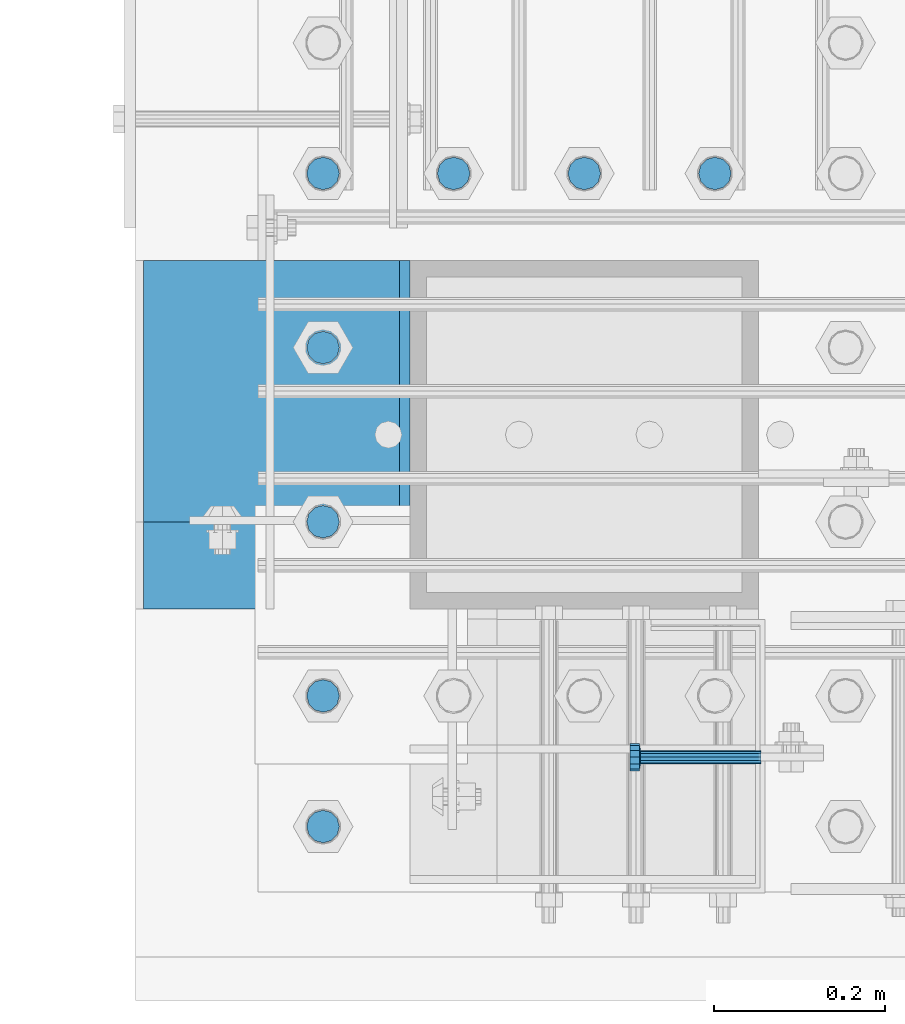
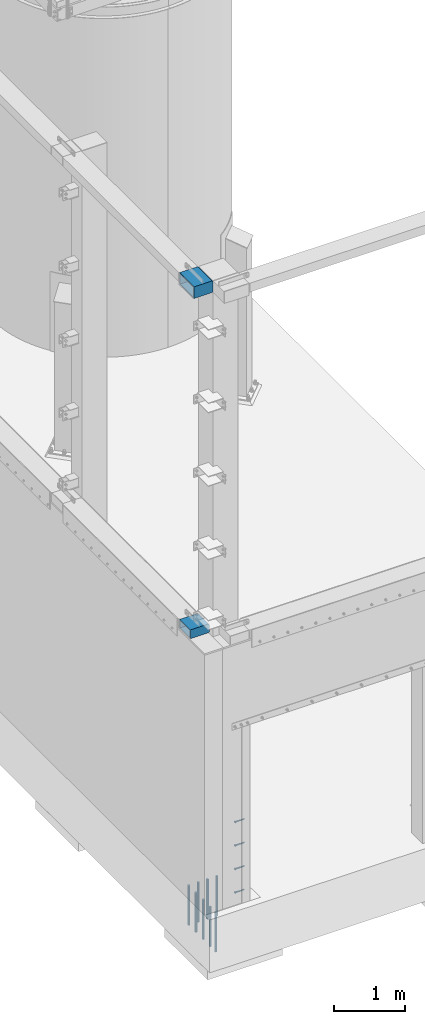
# One storey, part 1081 of 1876: 14 beams, 3 elements without a shape of their own.
"""IFC2X3 building model written with IfcOpenShell, lengths in millimetres."""

from ifc_helpers import new_model, si_unit, frame, origin_with_axes, place, context, subcontext, project, spatial, faceted_brep, material, type_object, element, aggregate, save


model = new_model("IFC2X3")

# Units and contexts
model_context = context("Model", 3, precision=1e-05, world=origin_with_axes())
body_context = subcontext(model_context, "Body", "Model", "MODEL_VIEW")
ifc_project = project(units=[si_unit("LENGTHUNIT", "METRE", prefix="MILLI"), si_unit("AREAUNIT", "SQUARE_METRE"), si_unit("VOLUMEUNIT", "CUBIC_METRE"), si_unit("MASSUNIT", "GRAM", prefix="KILO"), si_unit("TIMEUNIT", "SECOND"), si_unit("PLANEANGLEUNIT", "RADIAN"), si_unit("SOLIDANGLEUNIT", "STERADIAN"), si_unit("THERMODYNAMICTEMPERATUREUNIT", "DEGREE_CELSIUS"), si_unit("LUMINOUSINTENSITYUNIT", "LUMEN")], contexts=[model_context])

# Site, building, storey
site_placement = place(None, origin_with_axes())
site = spatial("IfcSite", under=ifc_project, at=site_placement, CompositionType="ELEMENT")
building_placement = place(site_placement, origin_with_axes())
building = spatial("IfcBuilding", under=site, at=building_placement, Name="Undefined", CompositionType="ELEMENT")
storey_placement = place(building_placement, origin_with_axes())
storey = spatial("IfcBuildingStorey", under=building, at=storey_placement, Name="Undefined", CompositionType="ELEMENT", Elevation=0.0)

# Assembly, beam
assembly_1_placement = place(storey_placement, origin_with_axes())
assembly_1 = element("IfcElementAssembly", 1, at=assembly_1_placement, inside=storey, Name="COLUMN", AssemblyPlace="NOTDEFINED", PredefinedType="RIGID_FRAME")
ifc_material_1 = material()
beam_type_1 = type_object("IfcBeamType", Name="HSS12X6X1/2", PredefinedType="NOTDEFINED")
beam_1_placement = place(assembly_1_placement, frame((-292.100000000004, -25349.2, 4597.4), z_axis=(0.0, 1.0, 0.0), x_axis=(1.0, 0.0, 0.0)))
beam_1 = element("IfcBeam", 2, at=beam_1_placement, type_object=beam_type_1, material=ifc_material_1, Name="BEAM", ObjectType="HSS12X6X1/2", context=body_context, shape_type="Brep", body=[
    faceted_brep([(9.52499999999452, 63.5, 139.700000000001), (9.52499999999452, 63.5, -139.700000000001), (320.675000000004, 63.5, -139.700000000001), (320.675000000004, 63.5, 139.700000000001), (9.52499999999452, -76.1999999999998, -152.400000000001), (9.52499999999452, -76.1999999999998, 152.400000000001), (9.52499999999452, 76.1999999999998, 152.400000000001), (9.52499999999452, 76.1999999999998, -152.400000000001), (9.52499999999452, -63.5, 139.700000000001), (9.52499999999452, -63.5, -139.700000000001), (307.975000000012, 76.1999999999998, 152.400000000001), (307.975000000012, 76.1999999999998, -152.400000000001), (320.675000000004, 63.5000000000073, -152.400000000001), (320.675000000004, 63.5000000000073, 152.400000000001), (320.675000000004, -63.5000000000018, 152.400000000001), (320.675000000004, -63.5, 139.700000000001), (320.675000000004, -63.5, -139.700000000001), (320.675000000004, -63.5000000000018, -152.400000000001), (307.975000000006, -76.1999999999998, -152.400000000001), (307.975000000006, -76.1999999999998, 152.400000000001)], [[[0, 1, 2, 3]], [[4, 5, 6, 7], [0, 8, 9, 1]], [[7, 6, 10, 11]], [[2, 12, 11, 10, 13, 3]], [[3, 13, 14, 15]], [[8, 0, 3, 15]], [[9, 8, 15, 16]], [[1, 9, 16, 2]], [[12, 2, 16, 17]], [[4, 7, 11, 12, 17, 18]], [[5, 4, 18, 19]], [[13, 10, 6, 5, 19, 14]], [[18, 17, 16, 15, 14, 19]]]),
])

# Assembly, beams
assembly_2_placement = place(storey_placement, origin_with_axes())
assembly_2 = element("IfcElementAssembly", 3, at=assembly_2_placement, inside=storey, Name="BENT PLATE", AssemblyPlace="NOTDEFINED", PredefinedType="RIGID_FRAME")
ifc_material_2 = material(Name="STEEL/A108")
beam_type_2 = type_object("IfcBeamType", Name="STUD_5/8-DIA", PredefinedType="NOTDEFINED")
beam_2_placement = place(assembly_2_placement, frame((437.751629702038, -25776.2375096436, 1320.8), z_axis=(0.0, 0.0, 1.0), x_axis=(-1.0, 0.0, 0.0)))
beam_2 = element("IfcBeam", 4, at=beam_2_placement, type_object=beam_type_2, material=ifc_material_2, Name="WELDED HEADED STUD", ObjectType="STUD_5/8-DIA", context=body_context, shape_type="Brep", body=[
    faceted_brep([(0.0, -7.94000005722046, 0.0), (0.0, -6.86999988555908, -3.97000002861023), (140.207082738083, -6.86999988555908, -3.97000002861023), (140.207082738083, -7.94000005722046, 0.0), (0.0, -3.97000002861023, -6.86999988555908), (140.207082738083, -3.97000002861023, -6.86999988555908), (0.0, 0.0, -7.94000005722046), (140.207082738083, 0.0, -7.94000005722046), (0.0, 3.97000002861023, -6.86999988555908), (140.207082738083, 3.97000002861023, -6.86999988555908), (0.0, 6.86999988555908, -3.97000002861023), (140.207082738083, 6.86999988555908, -3.97000002861023), (0.0, 7.94000005722046, 0.0), (140.207082738083, 7.94000005722046, 0.0), (0.0, 6.86999988555908, 3.97000002861023), (140.207082738083, 6.86999988555908, 3.97000002861023), (0.0, 3.97000002861023, 6.86999988555908), (140.207082738083, 3.97000002861023, 6.86999988555908), (0.0, 0.0, 7.94000005722046), (140.207082738083, 0.0, 7.94000005722046), (0.0, -3.97000002861023, 6.86999988555908), (140.207082738083, -3.97000002861023, 6.86999988555908), (0.0, -6.86999988555908, 3.97000002861023), (140.207082738083, -6.86999988555908, 3.97000002861023), (141.731072767845, -13.75, -7.94000005722046), (141.731072767845, -15.8800001144409, 0.0), (141.731072767845, -7.94000005722046, -13.75), (141.731072767845, 0.0, -15.8800001144409), (141.731072767845, 7.94000005722046, -13.75), (141.731072767845, 13.75, -7.94000005722046), (141.731072767845, 15.8800001144409, 0.0), (141.731072767845, 13.75, 7.94000005722046), (141.731072767845, 7.94000005722046, 13.75), (141.731072767845, 0.0, 15.8800001144409), (141.731072767845, -7.94000005722046, 13.75), (141.731072767845, -13.75, 7.94000005722046), (152.399002976177, -13.75, -7.94000005722046), (152.399002976177, -15.8800001144409, 0.0), (152.399002976177, -7.94000005722046, -13.75), (152.399002976177, 0.0, -15.8800001144409), (152.399002976177, 7.94000005722046, -13.75), (152.399002976177, 13.75, -7.94000005722046), (152.399002976177, 15.8800001144409, 0.0), (152.399002976177, 13.75, 7.94000005722046), (152.399002976177, 7.94000005722046, 13.75), (152.399002976177, 0.0, 15.8800001144409), (152.399002976177, -7.94000005722046, 13.75), (152.399002976177, -13.75, 7.94000005722046)], [[[0, 1, 2, 3]], [[1, 4, 5, 2]], [[4, 6, 7, 5]], [[6, 8, 9, 7]], [[8, 10, 11, 9]], [[10, 12, 13, 11]], [[12, 14, 15, 13]], [[14, 16, 17, 15]], [[16, 18, 19, 17]], [[18, 20, 21, 19]], [[20, 22, 23, 21]], [[22, 0, 3, 23]], [[22, 20, 18, 16, 14, 12, 10, 8, 6, 4, 1, 0]], [[3, 2, 24, 25]], [[2, 5, 26, 24]], [[5, 7, 27, 26]], [[7, 9, 28, 27]], [[9, 11, 29, 28]], [[11, 13, 30, 29]], [[13, 15, 31, 30]], [[15, 17, 32, 31]], [[17, 19, 33, 32]], [[19, 21, 34, 33]], [[21, 23, 35, 34]], [[23, 3, 25, 35]], [[25, 24, 36, 37]], [[24, 26, 38, 36]], [[26, 27, 39, 38]], [[27, 28, 40, 39]], [[28, 29, 41, 40]], [[29, 30, 42, 41]], [[30, 31, 43, 42]], [[31, 32, 44, 43]], [[32, 33, 45, 44]], [[33, 34, 46, 45]], [[34, 35, 47, 46]], [[35, 25, 37, 47]], [[38, 39, 40, 41, 42, 43, 44, 45, 46, 47, 37, 36]]]),
])
beam_3_placement = place(assembly_2_placement, frame((437.751629702038, -25776.2375096436, 914.4), z_axis=(0.0, 0.0, 1.0), x_axis=(-1.0, 0.0, 0.0)))
beam_3 = element("IfcBeam", 5, at=beam_3_placement, type_object=beam_type_2, material=ifc_material_2, Name="WELDED HEADED STUD", ObjectType="STUD_5/8-DIA", context=body_context, shape_type="Brep", body=[
    faceted_brep([(0.0, -7.94000005722046, 0.0), (0.0, -6.86999988555908, -3.97000002861023), (140.207082738083, -6.86999988555908, -3.97000002861023), (140.207082738083, -7.94000005722046, 0.0), (0.0, -3.97000002861023, -6.86999988555908), (140.207082738083, -3.97000002861023, -6.86999988555908), (0.0, 0.0, -7.94000005722046), (140.207082738083, 0.0, -7.94000005722046), (0.0, 3.97000002861023, -6.86999988555908), (140.207082738083, 3.97000002861023, -6.86999988555908), (0.0, 6.86999988555908, -3.97000002861023), (140.207082738083, 6.86999988555908, -3.97000002861023), (0.0, 7.94000005722046, 0.0), (140.207082738083, 7.94000005722046, 0.0), (0.0, 6.86999988555908, 3.97000002861023), (140.207082738083, 6.86999988555908, 3.97000002861023), (0.0, 3.97000002861023, 6.86999988555908), (140.207082738083, 3.97000002861023, 6.86999988555908), (0.0, 0.0, 7.94000005722046), (140.207082738083, 0.0, 7.94000005722046), (0.0, -3.97000002861023, 6.86999988555908), (140.207082738083, -3.97000002861023, 6.86999988555908), (0.0, -6.86999988555908, 3.97000002861023), (140.207082738083, -6.86999988555908, 3.97000002861023), (141.731072767845, -13.75, -7.94000005722046), (141.731072767845, -15.8800001144409, 0.0), (141.731072767845, -7.94000005722046, -13.75), (141.731072767845, 0.0, -15.8800001144409), (141.731072767845, 7.94000005722046, -13.75), (141.731072767845, 13.75, -7.94000005722046), (141.731072767845, 15.8800001144409, 0.0), (141.731072767845, 13.75, 7.94000005722046), (141.731072767845, 7.94000005722046, 13.75), (141.731072767845, 0.0, 15.8800001144409), (141.731072767845, -7.94000005722046, 13.75), (141.731072767845, -13.75, 7.94000005722046), (152.399002976177, -13.75, -7.94000005722046), (152.399002976177, -15.8800001144409, 0.0), (152.399002976177, -7.94000005722046, -13.75), (152.399002976177, 0.0, -15.8800001144409), (152.399002976177, 7.94000005722046, -13.75), (152.399002976177, 13.75, -7.94000005722046), (152.399002976177, 15.8800001144409, 0.0), (152.399002976177, 13.75, 7.94000005722046), (152.399002976177, 7.94000005722046, 13.75), (152.399002976177, 0.0, 15.8800001144409), (152.399002976177, -7.94000005722046, 13.75), (152.399002976177, -13.75, 7.94000005722046)], [[[0, 1, 2, 3]], [[1, 4, 5, 2]], [[4, 6, 7, 5]], [[6, 8, 9, 7]], [[8, 10, 11, 9]], [[10, 12, 13, 11]], [[12, 14, 15, 13]], [[14, 16, 17, 15]], [[16, 18, 19, 17]], [[18, 20, 21, 19]], [[20, 22, 23, 21]], [[22, 0, 3, 23]], [[22, 20, 18, 16, 14, 12, 10, 8, 6, 4, 1, 0]], [[3, 2, 24, 25]], [[2, 5, 26, 24]], [[5, 7, 27, 26]], [[7, 9, 28, 27]], [[9, 11, 29, 28]], [[11, 13, 30, 29]], [[13, 15, 31, 30]], [[15, 17, 32, 31]], [[17, 19, 33, 32]], [[19, 21, 34, 33]], [[21, 23, 35, 34]], [[23, 3, 25, 35]], [[25, 24, 36, 37]], [[24, 26, 38, 36]], [[26, 27, 39, 38]], [[27, 28, 40, 39]], [[28, 29, 41, 40]], [[29, 30, 42, 41]], [[30, 31, 43, 42]], [[31, 32, 44, 43]], [[32, 33, 45, 44]], [[33, 34, 46, 45]], [[34, 35, 47, 46]], [[35, 25, 37, 47]], [[38, 39, 40, 41, 42, 43, 44, 45, 46, 47, 37, 36]]]),
])
beam_4_placement = place(assembly_2_placement, frame((437.751629702038, -25776.2375096436, 508.0), z_axis=(0.0, 0.0, 1.0), x_axis=(-1.0, 0.0, 0.0)))
beam_4 = element("IfcBeam", 6, at=beam_4_placement, type_object=beam_type_2, material=ifc_material_2, Name="WELDED HEADED STUD", ObjectType="STUD_5/8-DIA", context=body_context, shape_type="Brep", body=[
    faceted_brep([(0.0, -7.94000005722046, 0.0), (0.0, -6.86999988555908, -3.97000002861023), (140.207082738083, -6.86999988555908, -3.97000002861023), (140.207082738083, -7.94000005722046, 0.0), (0.0, -3.97000002861023, -6.86999988555908), (140.207082738083, -3.97000002861023, -6.86999988555908), (0.0, 0.0, -7.94000005722046), (140.207082738083, 0.0, -7.94000005722046), (0.0, 3.97000002861023, -6.86999988555908), (140.207082738083, 3.97000002861023, -6.86999988555908), (0.0, 6.86999988555908, -3.97000002861023), (140.207082738083, 6.86999988555908, -3.97000002861023), (0.0, 7.94000005722046, 0.0), (140.207082738083, 7.94000005722046, 0.0), (0.0, 6.86999988555908, 3.97000002861023), (140.207082738083, 6.86999988555908, 3.97000002861023), (0.0, 3.97000002861023, 6.86999988555908), (140.207082738083, 3.97000002861023, 6.86999988555908), (0.0, 0.0, 7.94000005722046), (140.207082738083, 0.0, 7.94000005722046), (0.0, -3.97000002861023, 6.86999988555908), (140.207082738083, -3.97000002861023, 6.86999988555908), (0.0, -6.86999988555908, 3.97000002861023), (140.207082738083, -6.86999988555908, 3.97000002861023), (141.731072767845, -13.75, -7.94000005722046), (141.731072767845, -15.8800001144409, 0.0), (141.731072767845, -7.94000005722046, -13.75), (141.731072767845, 0.0, -15.8800001144409), (141.731072767845, 7.94000005722046, -13.75), (141.731072767845, 13.75, -7.94000005722046), (141.731072767845, 15.8800001144409, 0.0), (141.731072767845, 13.75, 7.94000005722046), (141.731072767845, 7.94000005722046, 13.75), (141.731072767845, 0.0, 15.8800001144409), (141.731072767845, -7.94000005722046, 13.75), (141.731072767845, -13.75, 7.94000005722046), (152.399002976177, -13.75, -7.94000005722046), (152.399002976177, -15.8800001144409, 0.0), (152.399002976177, -7.94000005722046, -13.75), (152.399002976177, 0.0, -15.8800001144409), (152.399002976177, 7.94000005722046, -13.75), (152.399002976177, 13.75, -7.94000005722046), (152.399002976177, 15.8800001144409, 0.0), (152.399002976177, 13.75, 7.94000005722046), (152.399002976177, 7.94000005722046, 13.75), (152.399002976177, 0.0, 15.8800001144409), (152.399002976177, -7.94000005722046, 13.75), (152.399002976177, -13.75, 7.94000005722046)], [[[0, 1, 2, 3]], [[1, 4, 5, 2]], [[4, 6, 7, 5]], [[6, 8, 9, 7]], [[8, 10, 11, 9]], [[10, 12, 13, 11]], [[12, 14, 15, 13]], [[14, 16, 17, 15]], [[16, 18, 19, 17]], [[18, 20, 21, 19]], [[20, 22, 23, 21]], [[22, 0, 3, 23]], [[22, 20, 18, 16, 14, 12, 10, 8, 6, 4, 1, 0]], [[3, 2, 24, 25]], [[2, 5, 26, 24]], [[5, 7, 27, 26]], [[7, 9, 28, 27]], [[9, 11, 29, 28]], [[11, 13, 30, 29]], [[13, 15, 31, 30]], [[15, 17, 32, 31]], [[17, 19, 33, 32]], [[19, 21, 34, 33]], [[21, 23, 35, 34]], [[23, 3, 25, 35]], [[25, 24, 36, 37]], [[24, 26, 38, 36]], [[26, 27, 39, 38]], [[27, 28, 40, 39]], [[28, 29, 41, 40]], [[29, 30, 42, 41]], [[30, 31, 43, 42]], [[31, 32, 44, 43]], [[32, 33, 45, 44]], [[33, 34, 46, 45]], [[34, 35, 47, 46]], [[35, 25, 37, 47]], [[38, 39, 40, 41, 42, 43, 44, 45, 46, 47, 37, 36]]]),
])
beam_5_placement = place(assembly_2_placement, frame((437.751629702038, -25776.2375096436, 101.6), z_axis=(0.0, 0.0, 1.0), x_axis=(-1.0, 0.0, 0.0)))
beam_5 = element("IfcBeam", 7, at=beam_5_placement, type_object=beam_type_2, material=ifc_material_2, Name="WELDED HEADED STUD", ObjectType="STUD_5/8-DIA", context=body_context, shape_type="Brep", body=[
    faceted_brep([(0.0, -7.94000005722046, 0.0), (0.0, -6.86999988555908, -3.97000002861023), (140.207082738083, -6.86999988555908, -3.97000002861023), (140.207082738083, -7.94000005722046, 0.0), (0.0, -3.97000002861023, -6.86999988555908), (140.207082738083, -3.97000002861023, -6.86999988555908), (0.0, 0.0, -7.94000005722046), (140.207082738083, 0.0, -7.94000005722046), (0.0, 3.97000002861023, -6.86999988555908), (140.207082738083, 3.97000002861023, -6.86999988555908), (0.0, 6.86999988555908, -3.97000002861023), (140.207082738083, 6.86999988555908, -3.97000002861023), (0.0, 7.94000005722046, 0.0), (140.207082738083, 7.94000005722046, 0.0), (0.0, 6.86999988555908, 3.97000002861023), (140.207082738083, 6.86999988555908, 3.97000002861023), (0.0, 3.97000002861023, 6.86999988555908), (140.207082738083, 3.97000002861023, 6.86999988555908), (0.0, 0.0, 7.94000005722046), (140.207082738083, 0.0, 7.94000005722046), (0.0, -3.97000002861023, 6.86999988555908), (140.207082738083, -3.97000002861023, 6.86999988555908), (0.0, -6.86999988555908, 3.97000002861023), (140.207082738083, -6.86999988555908, 3.97000002861023), (141.731072767845, -13.75, -7.94000005722046), (141.731072767845, -15.8800001144409, 0.0), (141.731072767845, -7.94000005722046, -13.75), (141.731072767845, 0.0, -15.8800001144409), (141.731072767845, 7.94000005722046, -13.75), (141.731072767845, 13.75, -7.94000005722046), (141.731072767845, 15.8800001144409, 0.0), (141.731072767845, 13.75, 7.94000005722046), (141.731072767845, 7.94000005722046, 13.75), (141.731072767845, 0.0, 15.8800001144409), (141.731072767845, -7.94000005722046, 13.75), (141.731072767845, -13.75, 7.94000005722046), (152.399002976177, -13.75, -7.94000005722046), (152.399002976177, -15.8800001144409, 0.0), (152.399002976177, -7.94000005722046, -13.75), (152.399002976177, 0.0, -15.8800001144409), (152.399002976177, 7.94000005722046, -13.75), (152.399002976177, 13.75, -7.94000005722046), (152.399002976177, 15.8800001144409, 0.0), (152.399002976177, 13.75, 7.94000005722046), (152.399002976177, 7.94000005722046, 13.75), (152.399002976177, 0.0, 15.8800001144409), (152.399002976177, -7.94000005722046, 13.75), (152.399002976177, -13.75, 7.94000005722046)], [[[0, 1, 2, 3]], [[1, 4, 5, 2]], [[4, 6, 7, 5]], [[6, 8, 9, 7]], [[8, 10, 11, 9]], [[10, 12, 13, 11]], [[12, 14, 15, 13]], [[14, 16, 17, 15]], [[16, 18, 19, 17]], [[18, 20, 21, 19]], [[20, 22, 23, 21]], [[22, 0, 3, 23]], [[22, 20, 18, 16, 14, 12, 10, 8, 6, 4, 1, 0]], [[3, 2, 24, 25]], [[2, 5, 26, 24]], [[5, 7, 27, 26]], [[7, 9, 28, 27]], [[9, 11, 29, 28]], [[11, 13, 30, 29]], [[13, 15, 31, 30]], [[15, 17, 32, 31]], [[17, 19, 33, 32]], [[19, 21, 34, 33]], [[21, 23, 35, 34]], [[23, 3, 25, 35]], [[25, 24, 36, 37]], [[24, 26, 38, 36]], [[26, 27, 39, 38]], [[27, 28, 40, 39]], [[28, 29, 41, 40]], [[29, 30, 42, 41]], [[30, 31, 43, 42]], [[31, 32, 44, 43]], [[32, 33, 45, 44]], [[33, 34, 46, 45]], [[34, 35, 47, 46]], [[35, 25, 37, 47]], [[38, 39, 40, 41, 42, 43, 44, 45, 46, 47, 37, 36]]]),
])
aggregate(assembly_2, [beam_2, beam_3, beam_4, beam_5])

# Beam
beam_type_3 = type_object("IfcBeamType", Name="HSS16X8X1/2", PredefinedType="NOTDEFINED")
beam_6_placement = place(assembly_1_placement, frame((-292.100000000004, -25400.0, 10566.4), z_axis=(0.0, 1.0, 0.0), x_axis=(1.0, 0.0, 0.0)))
beam_6 = element("IfcBeam", 8, at=beam_6_placement, type_object=beam_type_3, material=ifc_material_1, Name="BEAM", ObjectType="HSS16X8X1/2", context=body_context, shape_type="Brep", body=[
    faceted_brep([(320.675000000004, 88.8999999999978, 203.200000000001), (320.675000000004, 88.8999999999996, 190.5), (320.675000000004, 88.8999999999996, -190.5), (320.675000000004, 88.8999999999978, -203.200000000001), (308.580151367192, 101.6, -203.200000000001), (308.580151367192, 101.6, 203.200000000001), (9.52499999999452, -101.6, 203.200000000001), (9.52499999999452, -101.6, -203.200000000001), (308.580151367192, -101.6, -203.200000000001), (308.580151367192, -101.6, 203.200000000001), (9.52499999999452, 101.6, 203.200000000001), (9.52499999999452, 101.6, -203.200000000001), (9.52499999999452, 88.8999999999996, 190.5), (9.52499999999452, -88.8999999999996, 190.5), (9.52499999999452, -88.8999999999996, -190.5), (9.52499999999452, 88.8999999999996, -190.5), (320.675000000004, -88.8999999999996, 190.5), (320.675000000004, -88.8999999999996, -190.5), (320.675000000004, -88.9000000000015, 203.200000000001), (320.675000000004, -88.9000000000015, -203.200000000001)], [[[0, 1, 2, 3, 4, 5]], [[6, 7, 8, 9]], [[7, 6, 10, 11], [12, 13, 14, 15]], [[14, 13, 16, 17]], [[18, 9, 8, 19, 17, 16]], [[10, 6, 9, 18, 0, 5]], [[11, 10, 5, 4]], [[19, 8, 7, 11, 4, 3]], [[17, 19, 3, 2]], [[15, 14, 17, 2]], [[12, 15, 2, 1]], [[13, 12, 1, 16]], [[18, 16, 1, 0]]]),
])

aggregate(assembly_1, [beam_6, beam_1])

# Assembly, beams
assembly_3_placement = place(storey_placement, origin_with_axes())
assembly_3 = element("IfcElementAssembly", 9, at=assembly_3_placement, inside=storey, Name="PLATE", AssemblyPlace="NOTDEFINED", PredefinedType="RIGID_FRAME")
ifc_material_3 = material(Name="STEEL/F1554-55, S1")
beam_type_4 = type_object("IfcBeamType", PredefinedType="NOTDEFINED")
beam_7_placement = place(assembly_3_placement, frame((384.174995628024, -25095.2000013791, -57.1499999999993), z_axis=(0.0, -1.0, 0.0), x_axis=(0.0, 0.0, -1.0)))
beam_7 = element("IfcBeam", 10, at=beam_7_placement, type_object=beam_type_4, material=ifc_material_3, Name="WELDED ANCHORS", context=body_context, shape_type="Brep", body=[
    faceted_brep([(0.0, -19.0500000000002, 0.0), (0.0, -16.4977839420935, -9.52500000000146), (685.799999999999, -16.4977839420936, -9.52500000000146), (685.799999999999, -19.05, 0.0), (0.0, -9.52500000000009, -16.4977839420935), (685.799999999999, -9.52499999999998, -16.4977839420935), (0.0, 0.0, -19.05), (685.799999999999, 0.0, -19.0499999999993), (0.0, 9.52500000000009, -16.4977839420935), (685.799999999999, 9.52500000000003, -16.4977839420935), (0.0, 16.4977839420935, -9.52500000000146), (685.799999999999, 16.4977839420936, -9.52500000000146), (-9.09494701772928e-13, 19.05, -1.81898940354586e-12), (685.799999999999, 19.05, 0.0), (0.0, 16.4977839420935, 9.52500000000146), (685.799999999999, 16.4977839420936, 9.52500000000146), (0.0, 9.52500000000009, 16.4977839420935), (685.799999999999, 9.52499999999998, 16.4977839420935), (0.0, 0.0, 19.0499999999993), (685.799999999999, 0.0, 19.0499999999993), (0.0, -9.52500000000009, 16.4977839420935), (685.799999999999, -9.52499999999998, 16.4977839420935), (0.0, -16.4977839420935, 9.52500000000146), (685.799999999999, -16.4977839420936, 9.52500000000146)], [[[0, 1, 2, 3]], [[1, 4, 5, 2]], [[4, 6, 7, 5]], [[6, 8, 9, 7]], [[8, 10, 11, 9]], [[10, 12, 13, 11]], [[12, 14, 15, 13]], [[14, 16, 17, 15]], [[16, 18, 19, 17]], [[18, 20, 21, 19]], [[20, 22, 23, 21]], [[22, 0, 3, 23]], [[5, 7, 9, 11, 13, 15, 17, 19, 21, 23, 3, 2]], [[22, 20, 18, 16, 14, 12, 10, 8, 6, 4, 1, 0]]]),
])
beam_8_placement = place(assembly_3_placement, frame((231.774995628024, -25095.2000027507, -57.1499999999993), z_axis=(0.0, -1.0, 0.0), x_axis=(0.0, 0.0, -1.0)))
beam_8 = element("IfcBeam", 11, at=beam_8_placement, type_object=beam_type_4, material=ifc_material_3, Name="WELDED ANCHORS", context=body_context, shape_type="Brep", body=[
    faceted_brep([(0.0, -19.0500000000002, 0.0), (0.0, -16.4977839420935, -9.52500000000146), (685.799999999999, -16.4977839420936, -9.52500000000146), (685.799999999999, -19.05, 0.0), (0.0, -9.52500000000009, -16.4977839420935), (685.799999999999, -9.52499999999998, -16.4977839420935), (0.0, 0.0, -19.05), (685.799999999999, 0.0, -19.0499999999993), (0.0, 9.52500000000009, -16.4977839420935), (685.799999999999, 9.52500000000003, -16.4977839420935), (0.0, 16.4977839420935, -9.52500000000146), (685.799999999999, 16.4977839420936, -9.52500000000146), (-9.09494701772928e-13, 19.05, -1.81898940354586e-12), (685.799999999999, 19.05, 0.0), (0.0, 16.4977839420935, 9.52500000000146), (685.799999999999, 16.4977839420936, 9.52500000000146), (0.0, 9.52500000000009, 16.4977839420935), (685.799999999999, 9.52499999999998, 16.4977839420935), (0.0, 0.0, 19.0499999999993), (685.799999999999, 0.0, 19.0499999999993), (0.0, -9.52500000000009, 16.4977839420935), (685.799999999999, -9.52499999999998, 16.4977839420935), (0.0, -16.4977839420935, 9.52500000000146), (685.799999999999, -16.4977839420936, 9.52500000000146)], [[[0, 1, 2, 3]], [[1, 4, 5, 2]], [[4, 6, 7, 5]], [[6, 8, 9, 7]], [[8, 10, 11, 9]], [[10, 12, 13, 11]], [[12, 14, 15, 13]], [[14, 16, 17, 15]], [[16, 18, 19, 17]], [[18, 20, 21, 19]], [[20, 22, 23, 21]], [[22, 0, 3, 23]], [[5, 7, 9, 11, 13, 15, 17, 19, 21, 23, 3, 2]], [[22, 20, 18, 16, 14, 12, 10, 8, 6, 4, 1, 0]]]),
])
beam_9_placement = place(assembly_3_placement, frame((79.3749956280238, -25095.2000041223, -57.1499999999993), z_axis=(0.0, -1.0, 0.0), x_axis=(0.0, 0.0, -1.0)))
beam_9 = element("IfcBeam", 12, at=beam_9_placement, type_object=beam_type_4, material=ifc_material_3, Name="WELDED ANCHORS", context=body_context, shape_type="Brep", body=[
    faceted_brep([(0.0, -19.0500000000002, 0.0), (0.0, -16.4977839420935, -9.52500000000146), (685.799999999999, -16.4977839420936, -9.52500000000146), (685.799999999999, -19.05, 0.0), (0.0, -9.52500000000009, -16.4977839420935), (685.799999999999, -9.52499999999998, -16.4977839420935), (0.0, 0.0, -19.05), (685.799999999999, 0.0, -19.0499999999993), (0.0, 9.52500000000009, -16.4977839420935), (685.799999999999, 9.52500000000003, -16.4977839420935), (0.0, 16.4977839420935, -9.52500000000146), (685.799999999999, 16.4977839420936, -9.52500000000146), (-9.09494701772928e-13, 19.05, -1.81898940354586e-12), (685.799999999999, 19.05, 0.0), (0.0, 16.4977839420935, 9.52500000000146), (685.799999999999, 16.4977839420936, 9.52500000000146), (0.0, 9.52500000000009, 16.4977839420935), (685.799999999999, 9.52499999999998, 16.4977839420935), (0.0, 0.0, 19.0499999999993), (685.799999999999, 0.0, 19.0499999999993), (0.0, -9.52500000000009, 16.4977839420935), (685.799999999999, -9.52499999999998, 16.4977839420935), (0.0, -16.4977839420935, 9.52500000000146), (685.799999999999, -16.4977839420936, 9.52500000000146)], [[[0, 1, 2, 3]], [[1, 4, 5, 2]], [[4, 6, 7, 5]], [[6, 8, 9, 7]], [[8, 10, 11, 9]], [[10, 12, 13, 11]], [[12, 14, 15, 13]], [[14, 16, 17, 15]], [[16, 18, 19, 17]], [[18, 20, 21, 19]], [[20, 22, 23, 21]], [[22, 0, 3, 23]], [[5, 7, 9, 11, 13, 15, 17, 19, 21, 23, 3, 2]], [[22, 20, 18, 16, 14, 12, 10, 8, 6, 4, 1, 0]]]),
])
beam_10_placement = place(assembly_3_placement, frame((-73.0250005657348, -25704.8000054939, -57.1499999999993), z_axis=(0.0, -1.0, 0.0), x_axis=(0.0, 0.0, -1.0)))
beam_10 = element("IfcBeam", 13, at=beam_10_placement, type_object=beam_type_4, material=ifc_material_3, Name="WELDED ANCHORS", context=body_context, shape_type="Brep", body=[
    faceted_brep([(0.0, -19.0500000000002, 0.0), (0.0, -16.4977839420935, -9.52500000000146), (685.799999999999, -16.4977839420936, -9.52500000000146), (685.799999999999, -19.05, 0.0), (0.0, -9.52500000000009, -16.4977839420935), (685.799999999999, -9.52499999999998, -16.4977839420935), (0.0, 0.0, -19.05), (685.799999999999, 0.0, -19.0499999999993), (0.0, 9.52500000000009, -16.4977839420935), (685.799999999999, 9.52500000000003, -16.4977839420935), (0.0, 16.4977839420935, -9.52500000000146), (685.799999999999, 16.4977839420936, -9.52500000000146), (-9.09494701772928e-13, 19.05, -1.81898940354586e-12), (685.799999999999, 19.05, 0.0), (0.0, 16.4977839420935, 9.52500000000146), (685.799999999999, 16.4977839420936, 9.52500000000146), (0.0, 9.52500000000009, 16.4977839420935), (685.799999999999, 9.52499999999998, 16.4977839420935), (0.0, 0.0, 19.0499999999993), (685.799999999999, 0.0, 19.0499999999993), (0.0, -9.52500000000009, 16.4977839420935), (685.799999999999, -9.52499999999998, 16.4977839420935), (0.0, -16.4977839420935, 9.52500000000146), (685.799999999999, -16.4977839420936, 9.52500000000146)], [[[0, 1, 2, 3]], [[1, 4, 5, 2]], [[4, 6, 7, 5]], [[6, 8, 9, 7]], [[8, 10, 11, 9]], [[10, 12, 13, 11]], [[12, 14, 15, 13]], [[14, 16, 17, 15]], [[16, 18, 19, 17]], [[18, 20, 21, 19]], [[20, 22, 23, 21]], [[22, 0, 3, 23]], [[5, 7, 9, 11, 13, 15, 17, 19, 21, 23, 3, 2]], [[22, 20, 18, 16, 14, 12, 10, 8, 6, 4, 1, 0]]]),
])
beam_11_placement = place(assembly_3_placement, frame((-73.0250005657348, -25095.2000054939, -57.1499999999993), z_axis=(0.0, -1.0, 0.0), x_axis=(0.0, 0.0, -1.0)))
beam_11 = element("IfcBeam", 14, at=beam_11_placement, type_object=beam_type_4, material=ifc_material_3, Name="WELDED ANCHORS", context=body_context, shape_type="Brep", body=[
    faceted_brep([(0.0, -19.0500000000002, 0.0), (0.0, -16.4977839420935, -9.52500000000146), (685.799999999999, -16.4977839420936, -9.52500000000146), (685.799999999999, -19.05, 0.0), (0.0, -9.52500000000009, -16.4977839420935), (685.799999999999, -9.52499999999998, -16.4977839420935), (0.0, 0.0, -19.05), (685.799999999999, 0.0, -19.0499999999993), (0.0, 9.52500000000009, -16.4977839420935), (685.799999999999, 9.52500000000003, -16.4977839420935), (0.0, 16.4977839420935, -9.52500000000146), (685.799999999999, 16.4977839420936, -9.52500000000146), (-9.09494701772928e-13, 19.05, -1.81898940354586e-12), (685.799999999999, 19.05, 0.0), (0.0, 16.4977839420935, 9.52500000000146), (685.799999999999, 16.4977839420936, 9.52500000000146), (0.0, 9.52500000000009, 16.4977839420935), (685.799999999999, 9.52499999999998, 16.4977839420935), (0.0, 0.0, 19.0499999999993), (685.799999999999, 0.0, 19.0499999999993), (0.0, -9.52500000000009, 16.4977839420935), (685.799999999999, -9.52499999999998, 16.4977839420935), (0.0, -16.4977839420935, 9.52500000000146), (685.799999999999, -16.4977839420936, 9.52500000000146)], [[[0, 1, 2, 3]], [[1, 4, 5, 2]], [[4, 6, 7, 5]], [[6, 8, 9, 7]], [[8, 10, 11, 9]], [[10, 12, 13, 11]], [[12, 14, 15, 13]], [[14, 16, 17, 15]], [[16, 18, 19, 17]], [[18, 20, 21, 19]], [[20, 22, 23, 21]], [[22, 0, 3, 23]], [[5, 7, 9, 11, 13, 15, 17, 19, 21, 23, 3, 2]], [[22, 20, 18, 16, 14, 12, 10, 8, 6, 4, 1, 0]]]),
])
beam_12_placement = place(assembly_3_placement, frame((-73.0250005657348, -25298.4000054939, -57.1499999999993), z_axis=(0.0, -1.0, 0.0), x_axis=(0.0, 0.0, -1.0)))
beam_12 = element("IfcBeam", 15, at=beam_12_placement, type_object=beam_type_4, material=ifc_material_3, Name="WELDED ANCHORS", context=body_context, shape_type="Brep", body=[
    faceted_brep([(0.0, -19.0500000000002, 0.0), (0.0, -16.4977839420935, -9.52500000000146), (685.799999999999, -16.4977839420936, -9.52500000000146), (685.799999999999, -19.05, 0.0), (0.0, -9.52500000000009, -16.4977839420935), (685.799999999999, -9.52499999999998, -16.4977839420935), (0.0, 0.0, -19.05), (685.799999999999, 0.0, -19.0499999999993), (0.0, 9.52500000000009, -16.4977839420935), (685.799999999999, 9.52500000000003, -16.4977839420935), (0.0, 16.4977839420935, -9.52500000000146), (685.799999999999, 16.4977839420936, -9.52500000000146), (-9.09494701772928e-13, 19.05, -1.81898940354586e-12), (685.799999999999, 19.05, 0.0), (0.0, 16.4977839420935, 9.52500000000146), (685.799999999999, 16.4977839420936, 9.52500000000146), (0.0, 9.52500000000009, 16.4977839420935), (685.799999999999, 9.52499999999998, 16.4977839420935), (0.0, 0.0, 19.0499999999993), (685.799999999999, 0.0, 19.0499999999993), (0.0, -9.52500000000009, 16.4977839420935), (685.799999999999, -9.52499999999998, 16.4977839420935), (0.0, -16.4977839420935, 9.52500000000146), (685.799999999999, -16.4977839420936, 9.52500000000146)], [[[0, 1, 2, 3]], [[1, 4, 5, 2]], [[4, 6, 7, 5]], [[6, 8, 9, 7]], [[8, 10, 11, 9]], [[10, 12, 13, 11]], [[12, 14, 15, 13]], [[14, 16, 17, 15]], [[16, 18, 19, 17]], [[18, 20, 21, 19]], [[20, 22, 23, 21]], [[22, 0, 3, 23]], [[5, 7, 9, 11, 13, 15, 17, 19, 21, 23, 3, 2]], [[22, 20, 18, 16, 14, 12, 10, 8, 6, 4, 1, 0]]]),
])
beam_13_placement = place(assembly_3_placement, frame((-73.0250005657348, -25501.6000054939, -57.1499999999993), z_axis=(0.0, -1.0, 0.0), x_axis=(0.0, 0.0, -1.0)))
beam_13 = element("IfcBeam", 16, at=beam_13_placement, type_object=beam_type_4, material=ifc_material_3, Name="WELDED ANCHORS", context=body_context, shape_type="Brep", body=[
    faceted_brep([(0.0, -19.0500000000002, 0.0), (0.0, -16.4977839420935, -9.52500000000146), (685.799999999999, -16.4977839420936, -9.52500000000146), (685.799999999999, -19.05, 0.0), (0.0, -9.52500000000009, -16.4977839420935), (685.799999999999, -9.52499999999998, -16.4977839420935), (0.0, 0.0, -19.05), (685.799999999999, 0.0, -19.0499999999993), (0.0, 9.52500000000009, -16.4977839420935), (685.799999999999, 9.52500000000003, -16.4977839420935), (0.0, 16.4977839420935, -9.52500000000146), (685.799999999999, 16.4977839420936, -9.52500000000146), (-9.09494701772928e-13, 19.05, -1.81898940354586e-12), (685.799999999999, 19.05, 0.0), (0.0, 16.4977839420935, 9.52500000000146), (685.799999999999, 16.4977839420936, 9.52500000000146), (0.0, 9.52500000000009, 16.4977839420935), (685.799999999999, 9.52499999999998, 16.4977839420935), (0.0, 0.0, 19.0499999999993), (685.799999999999, 0.0, 19.0499999999993), (0.0, -9.52500000000009, 16.4977839420935), (685.799999999999, -9.52499999999998, 16.4977839420935), (0.0, -16.4977839420935, 9.52500000000146), (685.799999999999, -16.4977839420936, 9.52500000000146)], [[[0, 1, 2, 3]], [[1, 4, 5, 2]], [[4, 6, 7, 5]], [[6, 8, 9, 7]], [[8, 10, 11, 9]], [[10, 12, 13, 11]], [[12, 14, 15, 13]], [[14, 16, 17, 15]], [[16, 18, 19, 17]], [[18, 20, 21, 19]], [[20, 22, 23, 21]], [[22, 0, 3, 23]], [[5, 7, 9, 11, 13, 15, 17, 19, 21, 23, 3, 2]], [[22, 20, 18, 16, 14, 12, 10, 8, 6, 4, 1, 0]]]),
])
beam_14_placement = place(assembly_3_placement, frame((-73.0250005657348, -25857.2000054939, -57.1499999999993), z_axis=(0.0, -1.0, 0.0), x_axis=(0.0, 0.0, -1.0)))
beam_14 = element("IfcBeam", 17, at=beam_14_placement, type_object=beam_type_4, material=ifc_material_3, Name="WELDED ANCHORS", context=body_context, shape_type="Brep", body=[
    faceted_brep([(0.0, -19.0500000000002, 0.0), (0.0, -16.4977839420935, -9.52500000000146), (685.799999999999, -16.4977839420936, -9.52500000000146), (685.799999999999, -19.05, 0.0), (0.0, -9.52500000000009, -16.4977839420935), (685.799999999999, -9.52499999999998, -16.4977839420935), (0.0, 0.0, -19.05), (685.799999999999, 0.0, -19.0499999999993), (0.0, 9.52500000000009, -16.4977839420935), (685.799999999999, 9.52500000000003, -16.4977839420935), (0.0, 16.4977839420935, -9.52500000000146), (685.799999999999, 16.4977839420936, -9.52500000000146), (-9.09494701772928e-13, 19.05, -1.81898940354586e-12), (685.799999999999, 19.05, 0.0), (0.0, 16.4977839420935, 9.52500000000146), (685.799999999999, 16.4977839420936, 9.52500000000146), (0.0, 9.52500000000009, 16.4977839420935), (685.799999999999, 9.52499999999998, 16.4977839420935), (0.0, 0.0, 19.0499999999993), (685.799999999999, 0.0, 19.0499999999993), (0.0, -9.52500000000009, 16.4977839420935), (685.799999999999, -9.52499999999998, 16.4977839420935), (0.0, -16.4977839420935, 9.52500000000146), (685.799999999999, -16.4977839420936, 9.52500000000146)], [[[0, 1, 2, 3]], [[1, 4, 5, 2]], [[4, 6, 7, 5]], [[6, 8, 9, 7]], [[8, 10, 11, 9]], [[10, 12, 13, 11]], [[12, 14, 15, 13]], [[14, 16, 17, 15]], [[16, 18, 19, 17]], [[18, 20, 21, 19]], [[20, 22, 23, 21]], [[22, 0, 3, 23]], [[5, 7, 9, 11, 13, 15, 17, 19, 21, 23, 3, 2]], [[22, 20, 18, 16, 14, 12, 10, 8, 6, 4, 1, 0]]]),
])
aggregate(assembly_3, [beam_7, beam_8, beam_9, beam_10, beam_11, beam_12, beam_13, beam_14])

save(model, "model.ifc")
